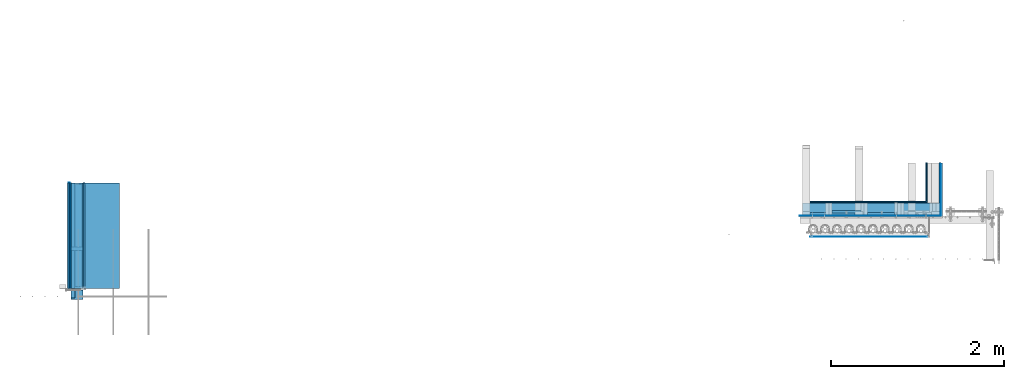
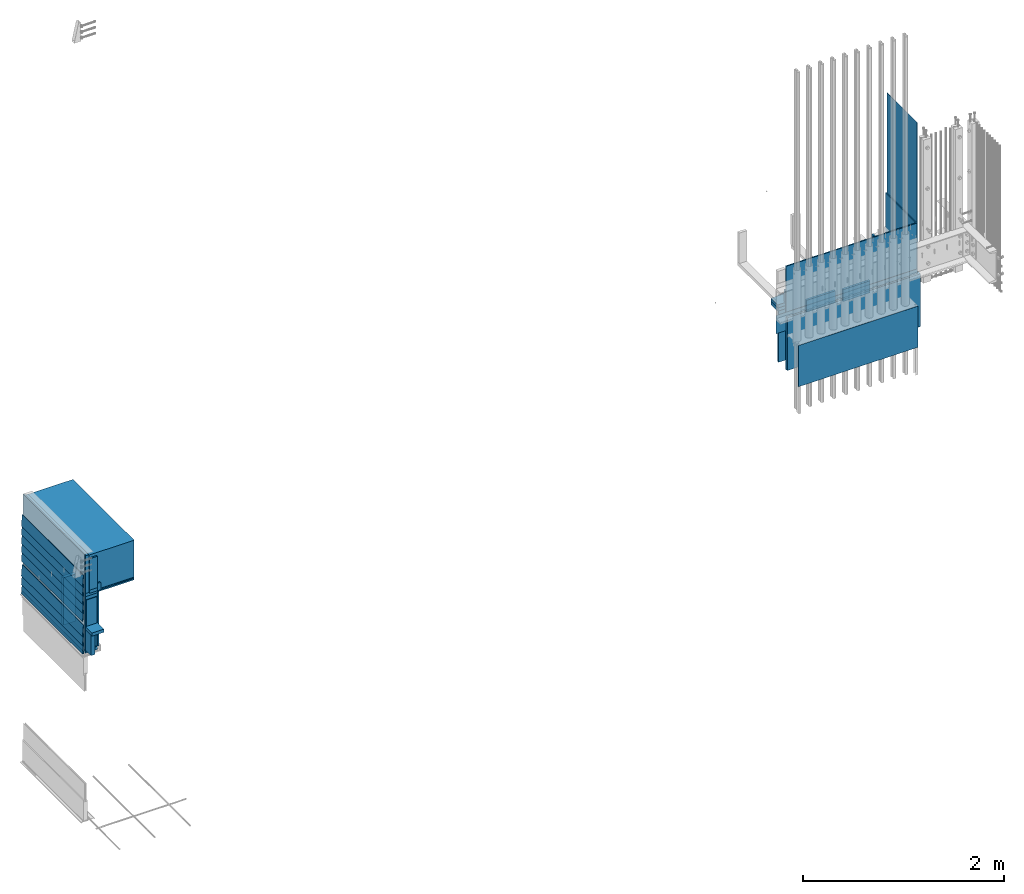
# One storey, part 1 of 44: 36 walls.
"""IFC4 building model written with IfcOpenShell, lengths in feet."""

import ifcopenshell
import ifcopenshell.guid

model = None  # the IFC model being written
_history = None  # IfcOwnerHistory: only IFC2X3 demands one
_inside = {}  # id of a spatial element -> (the spatial element, [elements in it])
_under = {}  # id of a project, library or spatial element -> (it, [spatial elements below it])
_declared = {}  # id of a project -> (the project, [libraries it declares])
_typed = {}  # id of a type object -> (the type object, [elements of that type])
_made_of = {}  # id of a material, layer set ... -> (it, [elements and type objects made of it])


def new_model(schema):
    """Start an empty IFC model of exactly this schema.

    Asked for "IFC4X3", IfcOpenShell would pick the latest addendum, in which some entities
    have other attributes; the version numbers below select the first issue.
    IFC2X3 requires an IfcOwnerHistory on every rooted entity: one is made here for all.
    """
    global model, _history
    if schema == "IFC4X3":
        model = ifcopenshell.file(schema_version=(4, 3, 0, 0))
    else:
        model = ifcopenshell.file(schema=schema)
    _inside.clear()
    _under.clear()
    _declared.clear()
    _typed.clear()
    _made_of.clear()
    _history = None
    if model.schema == "IFC2X3":
        org = make("IfcOrganization", Name="unknown")
        user = make(
            "IfcPersonAndOrganization",
            ThePerson=make("IfcPerson", FamilyName="unknown"),
            TheOrganization=org,
        )
        app = make(
            "IfcApplication",
            ApplicationDeveloper=org,
            Version="unknown",
            ApplicationFullName="unknown",
            ApplicationIdentifier="unknown",
        )
        _history = make(
            "IfcOwnerHistory",
            OwningUser=user,
            OwningApplication=app,
            ChangeAction="ADDED",
            CreationDate=0,
        )
    return model


def make(cls, **values):
    """One entity of the class cls with the attributes given. An attribute that is None is left unset."""
    return model.create_entity(
        cls, **{name: value for name, value in values.items() if value is not None}
    )


def entity(cls, *values):
    """Any entity or typed value of the class cls, its attributes in the order of the schema. None: left unset."""
    e = model.create_entity(cls)
    for i, value in enumerate(values):
        if value is not None:
            e[i] = value
    return e


def rooted(cls, **values):
    """An entity with a GlobalId (a new one), such as an element, a storey or a relation."""
    return make(cls, GlobalId=ifcopenshell.guid.new(), OwnerHistory=_history, **values)


def si_unit(unit_type, name, prefix=None):
    """IfcSIUnit, for example si_unit("LENGTHUNIT", "METRE", prefix="MILLI")."""
    return make("IfcSIUnit", UnitType=unit_type, Prefix=prefix, Name=name)


def converted_unit(unit_type, name, factor, base, dimensions=None, offset=None):
    """IfcConversionBasedUnit, such as the inch: factor (a typed value) times the base unit."""
    return make(
        "IfcConversionBasedUnit"
        if offset is None
        else "IfcConversionBasedUnitWithOffset",
        ConversionOffset=offset,
        Dimensions=None
        if dimensions is None
        else entity("IfcDimensionalExponents", *dimensions),
        UnitType=unit_type,
        Name=name,
        ConversionFactor=make(
            "IfcMeasureWithUnit", ValueComponent=factor, UnitComponent=base
        ),
    )


def derived_unit(unit_type, elements):
    """IfcDerivedUnit: a product of units, each with its exponent."""
    return make(
        "IfcDerivedUnit",
        Elements=[
            make("IfcDerivedUnitElement", Unit=unit, Exponent=power)
            for unit, power in elements
        ],
        UnitType=unit_type,
    )


def assignment(units):
    """IfcUnitAssignment: the units of a project."""
    return None if units is None else make("IfcUnitAssignment", Units=units)


def point(xyz):
    """IfcCartesianPoint."""
    return None if xyz is None else make("IfcCartesianPoint", Coordinates=xyz)


def direction(xyz):
    """IfcDirection."""
    return None if xyz is None else make("IfcDirection", DirectionRatios=xyz)


def frame(location, z_axis=None, x_axis=None):
    """IfcAxis2Placement3D, a coordinate frame: its origin and axes. An axis left out is left unset."""
    return make(
        "IfcAxis2Placement3D",
        Location=point(location),
        Axis=direction(z_axis),
        RefDirection=direction(x_axis),
    )


def frame_2d(location, x_axis=None):
    """IfcAxis2Placement2D, a coordinate frame in the plane: its origin and x axis."""
    return make(
        "IfcAxis2Placement2D", Location=point(location), RefDirection=direction(x_axis)
    )


def origin():
    """The frame at (0, 0, 0) with its axes left unset."""
    return frame((0.0, 0.0, 0.0))


def origin_2d_with_axis():
    """The frame at (0, 0) in the plane with the x axis (1, 0) written out."""
    return frame_2d((0.0, 0.0), x_axis=(1.0, 0.0))


def place(relative_to, where):
    """IfcLocalPlacement: puts the frame where relative to a parent placement (None: the world)."""
    return make(
        "IfcLocalPlacement", PlacementRelTo=relative_to, RelativePlacement=where
    )


def context(
    kind, dimensions, precision=None, world=None, true_north=None, identifier=None
):
    """IfcGeometricRepresentationContext, for example the 3D "Model" context."""
    return make(
        "IfcGeometricRepresentationContext",
        ContextIdentifier=identifier,
        ContextType=kind,
        CoordinateSpaceDimension=dimensions,
        Precision=precision,
        WorldCoordinateSystem=world,
        TrueNorth=true_north,
    )


def subcontext(parent, identifier, kind, view, scale=None):
    """IfcGeometricRepresentationSubContext, for example "Body" below "Model"."""
    return make(
        "IfcGeometricRepresentationSubContext",
        ContextIdentifier=identifier,
        ContextType=kind,
        ParentContext=parent,
        TargetScale=scale,
        TargetView=view,
    )


def project(units=None, contexts=None):
    """IfcProject with its units and contexts."""
    return rooted(
        "IfcProject",
        Name="project",
        RepresentationContexts=contexts,
        UnitsInContext=assignment(units),
    )


def spatial(cls, under=None, at=None, **own):
    """A site, building, storey or space (cls), placed at a placement, below another one or the project."""
    s = rooted(cls, ObjectPlacement=at, **own)
    if under is not None:
        _under.setdefault(under.id(), (under, []))[1].append(s)
    return s


def polyline(points):
    """IfcPolyline through the points."""
    return make("IfcPolyline", Points=[point(p) for p in points])


def profile(cls, at=None, kind="AREA", **sizes):
    """A parametric profile (cls). Its sizes go by their IFC names, for example OverallWidth=200.0."""
    return make(cls, ProfileType=kind, Position=at, **sizes)


def rectangle(**sizes):
    """IfcRectangleProfileDef."""
    return profile("IfcRectangleProfileDef", **sizes)


def outline(outer, holes=None, kind="AREA"):
    """IfcArbitraryClosedProfileDef: a profile drawn as a closed curve; with holes, ...WithVoids."""
    if holes is None:
        return make("IfcArbitraryClosedProfileDef", ProfileType=kind, OuterCurve=outer)
    return make(
        "IfcArbitraryProfileDefWithVoids",
        ProfileType=kind,
        OuterCurve=outer,
        InnerCurves=holes,
    )


def extrude(swept, where, along, depth):
    """IfcExtrudedAreaSolid: the profile swept, set in the frame where, extruded along a direction by depth."""
    return make(
        "IfcExtrudedAreaSolid",
        SweptArea=swept,
        Position=where,
        ExtrudedDirection=direction(along),
        Depth=depth,
    )


def shape(context_of_items, identifier, shape_type, items):
    """IfcShapeRepresentation: the items that make up one representation, for example the "Body"."""
    return make(
        "IfcShapeRepresentation",
        ContextOfItems=context_of_items,
        RepresentationIdentifier=identifier,
        RepresentationType=shape_type,
        Items=items,
    )


def material(Name=None, Category=None):
    """IfcMaterial."""
    return make("IfcMaterial", Name=Name, Category=Category)


def made_of(thing, what):
    """Note that an element or type object is made of a material, layer set ...; save() writes the relation."""
    if what is not None:
        _made_of.setdefault(what.id(), (what, []))[1].append(thing)
    return thing


def type_object(cls, material=None, **own):
    """A type object (cls), such as IfcWallType, which elements share."""
    return made_of(rooted(cls, **own), material)


def element(
    cls,
    number,
    at=None,
    inside=None,
    cuts=None,
    type_object=None,
    material=None,
    context=None,
    identifier="Body",
    shape_type=None,
    held_by="IfcProductDefinitionShape",
    body=None,
    shapes=None,
    **own,
):
    """One element of the class cls, such as IfcWall. Its Tag is "e" and its number.

    at: its placement. inside: the storey or other place that contains it. cuts: it is an
    opening in that element (IfcRelVoidsElement). A single representation is given by context,
    identifier, shape_type and body (its items); several are given by shapes. held_by: the class
    of the entity that holds the representations. save() writes the other relations.
    """
    e = rooted(cls, Tag="e%d" % number, ObjectPlacement=at, **own)
    if body is not None:
        shapes = [shape(context, identifier, shape_type, body)]
    if shapes is not None:
        e.Representation = make(held_by, Representations=shapes)
    if inside is not None:
        _inside.setdefault(inside.id(), (inside, []))[1].append(e)
    if cuts is not None:
        rooted(
            "IfcRelVoidsElement", RelatingBuildingElement=cuts, RelatedOpeningElement=e
        )
    if type_object is not None:
        _typed.setdefault(type_object.id(), (type_object, []))[1].append(e)
    return made_of(e, material)


def aggregate(whole, parts):
    """IfcRelAggregates: a whole, such as a stair, and the parts it consists of."""
    return rooted("IfcRelAggregates", RelatingObject=whole, RelatedObjects=parts)


def save(model, path):
    """Write the relations noted so far, then the file.

    IfcRelAggregates (storeys below a building ...), IfcRelContainedInSpatialStructure (elements
    in a storey), IfcRelDefinesByType, IfcRelAssociatesMaterial and IfcRelDeclares: one each for
    every whole, place, type object, material and project.
    """
    for whole, parts in _under.values():
        aggregate(whole, parts)
    for where, things in _inside.values():
        rooted(
            "IfcRelContainedInSpatialStructure",
            RelatedElements=things,
            RelatingStructure=where,
        )
    for kind, things in _typed.values():
        rooted("IfcRelDefinesByType", RelatedObjects=things, RelatingType=kind)
    for what, things in _made_of.values():
        rooted("IfcRelAssociatesMaterial", RelatedObjects=things, RelatingMaterial=what)
    for by, libraries in _declared.values():
        rooted("IfcRelDeclares", RelatingContext=by, RelatedDefinitions=libraries)
    model.write(path)


model = new_model("IFC4")

# Units and contexts
model_context = context("Model", 3, precision=0.0001, world=origin(), true_north=direction((6.12303176911189e-17, 1.0)))
body_context = subcontext(model_context, "Body", "Model", "MODEL_VIEW")
ifc_project = project(units=[converted_unit("LENGTHUNIT", "FOOT", entity("IfcRatioMeasure", 0.3048), si_unit("LENGTHUNIT", "METRE"), dimensions=[1, 0, 0, 0, 0, 0, 0]), converted_unit("AREAUNIT", "SQUARE FOOT", entity("IfcRatioMeasure", 0.09290304), si_unit("AREAUNIT", "SQUARE_METRE"), dimensions=[2, 0, 0, 0, 0, 0, 0]), converted_unit("VOLUMEUNIT", "CUBIC FOOT", entity("IfcRatioMeasure", 0.028316846592), si_unit("VOLUMEUNIT", "CUBIC_METRE"), dimensions=[3, 0, 0, 0, 0, 0, 0]), converted_unit("PLANEANGLEUNIT", "DEGREE", entity("IfcRatioMeasure", 0.0174532925199433), si_unit("PLANEANGLEUNIT", "RADIAN"), dimensions=[0, 0, 0, 0, 0, 0, 0]), si_unit("MASSUNIT", "GRAM", prefix="KILO"), derived_unit("MASSDENSITYUNIT", [(si_unit("MASSUNIT", "GRAM", prefix="KILO"), 1), (si_unit("LENGTHUNIT", "METRE"), -3)]), derived_unit("MOMENTOFINERTIAUNIT", [(si_unit("LENGTHUNIT", "METRE"), 4)]), si_unit("TIMEUNIT", "SECOND"), si_unit("FREQUENCYUNIT", "HERTZ"), si_unit("THERMODYNAMICTEMPERATUREUNIT", "DEGREE_CELSIUS"), derived_unit("THERMALTRANSMITTANCEUNIT", [(si_unit("MASSUNIT", "GRAM", prefix="KILO"), 1), (si_unit("THERMODYNAMICTEMPERATUREUNIT", "KELVIN"), -1), (si_unit("TIMEUNIT", "SECOND"), -3)]), derived_unit("VOLUMETRICFLOWRATEUNIT", [(si_unit("LENGTHUNIT", "METRE"), 3), (si_unit("TIMEUNIT", "SECOND"), -1)]), si_unit("ELECTRICCURRENTUNIT", "AMPERE"), si_unit("ELECTRICVOLTAGEUNIT", "VOLT"), si_unit("POWERUNIT", "WATT"), si_unit("FORCEUNIT", "NEWTON"), si_unit("ILLUMINANCEUNIT", "LUX"), si_unit("LUMINOUSFLUXUNIT", "LUMEN"), si_unit("LUMINOUSINTENSITYUNIT", "CANDELA"), derived_unit("USERDEFINED", [(si_unit("MASSUNIT", "GRAM", prefix="KILO"), -1), (si_unit("LENGTHUNIT", "METRE"), -2), (si_unit("TIMEUNIT", "SECOND"), 3), (si_unit("LUMINOUSFLUXUNIT", "LUMEN"), 1)]), derived_unit("LINEARVELOCITYUNIT", [(si_unit("LENGTHUNIT", "METRE"), 1), (si_unit("TIMEUNIT", "SECOND"), -1)]), si_unit("PRESSUREUNIT", "PASCAL"), derived_unit("USERDEFINED", [(si_unit("LENGTHUNIT", "METRE"), -2), (si_unit("MASSUNIT", "GRAM", prefix="KILO"), 1), (si_unit("TIMEUNIT", "SECOND"), -2)]), derived_unit("LINEARFORCEUNIT", [(si_unit("MASSUNIT", "GRAM", prefix="KILO"), 1), (si_unit("LENGTHUNIT", "METRE"), 1), (si_unit("TIMEUNIT", "SECOND"), -2), (si_unit("LENGTHUNIT", "METRE"), -1)]), derived_unit("PLANARFORCEUNIT", [(si_unit("MASSUNIT", "GRAM", prefix="KILO"), 1), (si_unit("LENGTHUNIT", "METRE"), 1), (si_unit("TIMEUNIT", "SECOND"), -2), (si_unit("LENGTHUNIT", "METRE"), -2)])], contexts=[model_context])

# Site, building, storey
site_placement = place(None, origin())
site = spatial("IfcSite", under=ifc_project, at=site_placement, CompositionType="ELEMENT")
building_placement = place(site_placement, origin())
building = spatial("IfcBuilding", under=site, at=building_placement, CompositionType="ELEMENT")
storey_placement = place(building_placement, origin())
storey = spatial("IfcBuildingStorey", under=building, at=storey_placement, CompositionType="ELEMENT", Elevation=0.0)

# Walls
ifc_material_1 = material(Name="WOOD TOP PLATE", Category="Materials")
wall_type_1 = type_object("IfcWallType", Name="Generic Models 630:Generic Models 1", PredefinedType="NOTDEFINED", material=ifc_material_1)
wall_1_placement = place(storey_placement, frame((1459.31080872048, 2.0, 6.71878516513966), z_axis=(0.0, 0.0, 1.0), x_axis=(0.0, 1.0, 0.0)))
element("IfcWall", 1, at=wall_1_placement, inside=storey, type_object=wall_type_1, material=ifc_material_1, Name="Generic Models 630:Generic Models 1", ObjectType="Generic Models 630:Generic Models 1", PredefinedType="NOTDEFINED", context=body_context, shape_type="SweptSolid", body=[
    extrude(rectangle(XDim=4.0, YDim=0.458333333333258, at=frame_2d((0.0, -1.13686837721616e-13), x_axis=(1.0, 0.0))), frame((2.0, -0.229166666666515, 0.0)), (0.0, 0.0, 1.0), 0.124999999999999),
])
ifc_material_2 = material(Name="DOUBLE 2X WOOD TOP PLATE", Category="Materials")
wall_type_2 = type_object("IfcWallType", Name="Generic Models 637:Generic Models 1", PredefinedType="NOTDEFINED", material=ifc_material_2)
wall_2_placement = place(storey_placement, frame((1459.31080872048, 2.0, 8.97916666666606), z_axis=(0.0, 0.0, 1.0), x_axis=(0.0, 1.0, 0.0)))
element("IfcWall", 2, at=wall_2_placement, inside=storey, type_object=wall_type_2, material=ifc_material_2, Name="Generic Models 637:Generic Models 1", ObjectType="Generic Models 637:Generic Models 1", PredefinedType="NOTDEFINED", context=body_context, shape_type="SweptSolid", body=[
    extrude(rectangle(XDim=4.0, YDim=0.458333333333485, at=frame_2d((0.0, -2.27373675443232e-13), x_axis=(1.0, 0.0))), frame((2.0, -0.229166666666515, 0.0)), (0.0, 0.0, 1.0), 0.125),
])
ifc_material_3 = material(Name="FIBER CEMENT", Category="Materials")
wall_type_3 = type_object("IfcWallType", Name="Generic Models 639:Generic Models 1", PredefinedType="NOTDEFINED", material=ifc_material_3)
wall_3_placement = place(storey_placement, frame((1459.19227841188, 2.0, 6.72139923807334), z_axis=(0.0, 0.0, 1.0), x_axis=(0.0, 1.0, 0.0)))
element("IfcWall", 3, at=wall_3_placement, inside=storey, type_object=wall_type_3, material=ifc_material_3, Name="Generic Models 639:Generic Models 1", ObjectType="Generic Models 639:Generic Models 1", PredefinedType="NOTDEFINED", context=body_context, shape_type="SweptSolid", body=[
    extrude(rectangle(XDim=0.0259999999998034, YDim=4.0, at=frame_2d((3.33066907387547e-16, 3.72965547335014e-17), x_axis=(0.0, 1.0))), frame((2.0, -0.0129531737923116, 0.0011024013350962), z_axis=(0.0, -0.0848001027001101, 0.996397984031507), x_axis=(1.0, 0.0, 0.0)), (0.0, 0.0, 1.0), 0.437499999999986),
])
ifc_material_4 = material(Name="2X WOOD STUD", Category="Materials")
wall_type_4 = type_object("IfcWallType", Name="Generic Models 645:Generic Models 1", PredefinedType="NOTDEFINED", material=ifc_material_4)
wall_4_placement = place(storey_placement, frame((1459.31080872048, 3.44270833332938, 6.96874999999967)))
element("IfcWall", 4, at=wall_4_placement, inside=storey, type_object=wall_type_4, material=ifc_material_4, Name="Generic Models 645:Generic Models 1", ObjectType="Generic Models 645:Generic Models 1", PredefinedType="NOTDEFINED", context=body_context, shape_type="SweptSolid", body=[
    extrude(rectangle(XDim=0.125000000000002, YDim=0.458333333333485, at=frame_2d((2.22044604925031e-16, 0.0), x_axis=(1.0, 0.0))), frame((0.229166666666742, 0.0625000000000009, 0.0), z_axis=(0.0, 0.0, 1.0), x_axis=(0.0, 1.0, 0.0)), (0.0, 0.0, 1.0), 1.8828124999993),
])
ifc_material_5 = material(Category="Materials")
wall_type_5 = type_object("IfcWallType", Name="Generic Models 650:Generic Models 1", PredefinedType="NOTDEFINED", material=ifc_material_5)
wall_5_placement = place(storey_placement, frame((1459.44707741189, 2.0, 9.12064598454291), z_axis=(0.0, 0.0, 1.0), x_axis=(0.0, 1.0, 0.0)))
element("IfcWall", 5, at=wall_5_placement, inside=storey, type_object=wall_type_5, material=ifc_material_5, Name="Generic Models 650:Generic Models 1", ObjectType="Generic Models 650:Generic Models 1", PredefinedType="NOTDEFINED", context=body_context, shape_type="SweptSolid", body=[
    extrude(rectangle(XDim=3.99999999999999, YDim=1.70028463773406, at=frame_2d((2.22044604925031e-16, -2.27373675443232e-13), x_axis=(1.0, 0.0))), frame((2.0, -0.850142318866801, 0.0)), (0.0, 0.0, 1.0), 1.47194541112943),
])
ifc_material_6 = material(Category="Materials")
wall_type_6 = type_object("IfcWallType", Name="Generic Models 653:Generic Models 1", PredefinedType="NOTDEFINED", material=ifc_material_6)
wall_6_placement = place(storey_placement, frame((1459.76914205382, 2.0, 6.84374999999967), z_axis=(0.0, 0.0, 1.0), x_axis=(0.0, 1.0, 0.0)))
element("IfcWall", 6, at=wall_6_placement, inside=storey, type_object=wall_type_6, material=ifc_material_6, Name="Generic Models 653:Generic Models 1", ObjectType="Generic Models 653:Generic Models 1", PredefinedType="NOTDEFINED", context=body_context, shape_type="SweptSolid", body=[
    extrude(rectangle(XDim=4.0, YDim=0.0520833333334849, at=origin_2d_with_axis()), frame((2.0, -0.0260416666667425, 0.0)), (0.0, 0.0, 1.0), 2.16666666666598),
])
ifc_material_7 = material(Name="LVL RIM BOARD - SEE STRUCT", Category="Materials")
wall_type_7 = type_object("IfcWallType", Name="Generic Models 660:Generic Models 1", PredefinedType="NOTDEFINED", material=ifc_material_7)
wall_7_placement = place(storey_placement, frame((1459.31080872048, 2.0, 9.10416666666608), z_axis=(0.0, 0.0, 1.0), x_axis=(0.0, 1.0, 0.0)))
element("IfcWall", 7, at=wall_7_placement, inside=storey, type_object=wall_type_7, material=ifc_material_7, Name="Generic Models 660:Generic Models 1", ObjectType="Generic Models 660:Generic Models 1", PredefinedType="NOTDEFINED", context=body_context, shape_type="SweptSolid", body=[
    extrude(rectangle(XDim=4.0, YDim=0.125, at=frame_2d((-2.22044604925031e-16, 0.0), x_axis=(1.0, 0.0))), frame((2.0, -0.0625, 0.0)), (0.0, 0.0, 1.0), 1.50054353157724),
])
wall_type_8 = type_object("IfcWallType", Name="Generic Models 669:Generic Models 1", PredefinedType="NOTDEFINED", material=ifc_material_2)
wall_8_placement = place(storey_placement, frame((1459.31080872048, 2.0, 8.85416666666564), z_axis=(0.0, 0.0, 1.0), x_axis=(0.0, 1.0, 0.0)))
element("IfcWall", 8, at=wall_8_placement, inside=storey, type_object=wall_type_8, material=ifc_material_2, Name="Generic Models 669:Generic Models 1", ObjectType="Generic Models 669:Generic Models 1", PredefinedType="NOTDEFINED", context=body_context, shape_type="SweptSolid", body=[
    extrude(rectangle(XDim=4.0, YDim=0.458333333333258, at=frame_2d((-5.55111512312578e-16, 1.13686837721616e-13), x_axis=(1.0, 0.0))), frame((2.0, -0.229166666666742, 0.0)), (0.0, 0.0, 1.0), 0.125),
])
ifc_material_8 = material(Name="STARTER STRIP", Category="Materials")
wall_type_9 = type_object("IfcWallType", Name="Generic Models 655:Generic Models 1", PredefinedType="NOTDEFINED", material=ifc_material_8)
wall_9_placement = place(storey_placement, frame((1459.22697042052, 2.0, 6.72046375490448), z_axis=(0.0, 0.0, 1.0), x_axis=(0.0, 1.0, 0.0)))
element("IfcWall", 9, at=wall_9_placement, inside=storey, type_object=wall_type_9, material=ifc_material_8, Name="Generic Models 655:Generic Models 1", ObjectType="Generic Models 655:Generic Models 1", PredefinedType="NOTDEFINED", context=body_context, shape_type="SweptSolid", body=[
    extrude(rectangle(XDim=4.0, YDim=0.022666666666737, at=frame_2d((4.44089209850063e-16, 0.0), x_axis=(1.0, 0.0))), frame((2.0, -0.0113333333333685, 0.0)), (0.0, 0.0, 1.0), 0.104166666666667),
])
ifc_material_9 = material(Category="Materials")
wall_type_10 = type_object("IfcWallType", Name="Generic Models 629:Generic Models 1", PredefinedType="NOTDEFINED", material=ifc_material_9)
wall_10_placement = place(storey_placement, frame((1459.76914205382, 2.0, 9.01041666666564), z_axis=(0.0, 0.0, 1.0), x_axis=(0.0, 1.0, 0.0)))
element("IfcWall", 10, at=wall_10_placement, inside=storey, type_object=wall_type_10, material=ifc_material_9, Name="Generic Models 629:Generic Models 1", ObjectType="Generic Models 629:Generic Models 1", PredefinedType="NOTDEFINED", context=body_context, shape_type="SweptSolid", body=[
    extrude(rectangle(XDim=4.0, YDim=1.37821999580524, at=frame_2d((0.0, -1.13686837721616e-13), x_axis=(1.0, 0.0))), frame((2.0, -0.689109997902506, 0.0)), (0.0, 0.0, 1.0), 0.0520833333333712),
])
ifc_material_10 = material(Name="LVL HEADER - SEE STRUCT", Category="Materials")
wall_type_11 = type_object("IfcWallType", Name="Walls 13:Walls 12", PredefinedType="NOTDEFINED", material=ifc_material_10)
wall_11_placement = place(storey_placement, frame((1459.31080872048, 1.64294860637011, 6.84378516513966), z_axis=(0.0, 0.0, 1.0), x_axis=(0.0, 1.0, 0.0)))
element("IfcWall", 11, at=wall_11_placement, inside=storey, type_object=wall_type_11, material=ifc_material_10, Name="Walls 13:Walls 12", ObjectType="Walls 13:Walls 12", PredefinedType="NOTDEFINED", context=body_context, shape_type="SweptSolid", body=[
    extrude(rectangle(XDim=4.35705139362589, YDim=0.145833333333258, at=frame_2d((2.22044604925031e-16, 1.13686837721616e-13), x_axis=(1.0, 0.0))), frame((2.17852569681294, -0.0729166666667425, 0.0)), (0.0, 0.0, 1.0), 0.8125),
])
ifc_material_11 = material(Category="Materials")
wall_type_12 = type_object("IfcWallType", Name="Generic Models 683:Generic Models 1", PredefinedType="NOTDEFINED", material=ifc_material_11)
wall_12_placement = place(storey_placement, frame((1459.26948162332, 2.0, 6.84374999999966), z_axis=(0.0, 0.0, 1.0), x_axis=(0.0, 1.0, 0.0)))
element("IfcWall", 12, at=wall_12_placement, inside=storey, type_object=wall_type_12, material=ifc_material_11, Name="Generic Models 683:Generic Models 1", ObjectType="Generic Models 683:Generic Models 1", PredefinedType="NOTDEFINED", context=body_context, shape_type="SweptSolid", body=[
    extrude(rectangle(XDim=4.0, YDim=0.0416666666667425, at=frame_2d((1.11022302462516e-16, 1.13686837721616e-13), x_axis=(1.0, 0.0))), frame((2.0, -0.0208333333334849, 0.0)), (0.0, 0.0, 1.0), 3.82346019824417),
])
ifc_material_12 = material(Name="BATT INSULATION - FILL CAVITY", Category="Materials")
wall_type_13 = type_object("IfcWallType", Name="Generic Models 684:Generic Models 1", PredefinedType="NOTDEFINED", material=ifc_material_12)
wall_13_placement = place(storey_placement, frame((1459.33910407653, 2.0, 6.86946636136536), z_axis=(0.0, 0.0, 1.0), x_axis=(0.0, 1.0, 0.0)))
element("IfcWall", 13, at=wall_13_placement, inside=storey, type_object=wall_type_13, material=ifc_material_12, Name="Generic Models 684:Generic Models 1", ObjectType="Generic Models 684:Generic Models 1", PredefinedType="NOTDEFINED", context=body_context, shape_type="SweptSolid", body=[
    extrude(rectangle(XDim=4.00000000000001, YDim=0.409204643948669, at=frame_2d((2.22044604925031e-16, 2.27373675443232e-13), x_axis=(1.0, 0.0))), frame((2.0, -0.204602321974562, 0.0)), (0.0, 0.0, 1.0), 1.96198692542525),
])
wall_type_14 = type_object("IfcWallType", Name="Generic Models 652:Generic Models 1", PredefinedType="NOTDEFINED", material=ifc_material_1)
wall_14_placement = place(storey_placement, frame((1459.31080872048, 1.58333333332933, 7.65628516513967), z_axis=(0.0, 0.0, 1.0), x_axis=(0.0, 1.0, 0.0)))
element("IfcWall", 14, at=wall_14_placement, inside=storey, type_object=wall_type_14, material=ifc_material_1, Name="Generic Models 652:Generic Models 1", ObjectType="Generic Models 652:Generic Models 1", PredefinedType="NOTDEFINED", context=body_context, shape_type="SweptSolid", body=[
    extrude(rectangle(XDim=4.0, YDim=0.458333333333258, at=frame_2d((-2.22044604925031e-16, -1.13686837721616e-13), x_axis=(1.0, 0.0))), frame((2.0, -0.229166666666515, 0.0)), (0.0, 0.0, 1.0), 0.124999999999999),
])
ifc_material_13 = material(Category="Materials")
wall_type_15 = type_object("IfcWallType", Name="Generic Models 698:Generic Models 1", PredefinedType="NOTDEFINED", material=ifc_material_13)
wall_15_placement = place(storey_placement, frame((1459.76914205382, 2.0, 9.06249999999901), z_axis=(0.0, 0.0, 1.0), x_axis=(0.0, 1.0, 0.0)))
element("IfcWall", 15, at=wall_15_placement, inside=storey, type_object=wall_type_15, material=ifc_material_13, Name="Generic Models 698:Generic Models 1", ObjectType="Generic Models 698:Generic Models 1", PredefinedType="NOTDEFINED", context=body_context, shape_type="SweptSolid", body=[
    extrude(rectangle(XDim=4.0, YDim=1.37821999580524, at=frame_2d((0.0, -1.13686837721616e-13), x_axis=(1.0, 0.0))), frame((2.0, -0.689109997902506, 0.0)), (0.0, 0.0, 1.0), 0.0416666666669343),
])
wall_type_16 = type_object("IfcWallType", Name="Generic Models 671:Generic Models 1", PredefinedType="NOTDEFINED", material=ifc_material_3)
wall_16_placement = place(storey_placement, frame((1459.1949158051, 2.0, 9.41517805258402), z_axis=(0.0, 0.0, 1.0), x_axis=(0.0, 1.0, 0.0)))
element("IfcWall", 16, at=wall_16_placement, inside=storey, type_object=wall_type_16, material=ifc_material_3, Name="Generic Models 671:Generic Models 1", ObjectType="Generic Models 671:Generic Models 1", PredefinedType="NOTDEFINED", context=body_context, shape_type="SweptSolid", body=[
    extrude(rectangle(XDim=0.0242384311178397, YDim=4.0, at=frame_2d((3.33066907387547e-16, 0.0), x_axis=(0.0, 1.0))), frame((2.0, -0.0120755619509509, 0.00102771072404551), z_axis=(0.0, -0.0848001027001742, 0.996397984031501), x_axis=(1.0, 0.0, 0.0)), (0.0, 0.0, 1.0), 0.437499999999987),
])
ifc_material_14 = material(Name="WOOD TRUSS - SEE STRUCT", Category="Materials")
wall_type_17 = type_object("IfcWallType", Name="Generic Models 673:Generic Models 1", PredefinedType="NOTDEFINED", material=ifc_material_14)
wall_17_placement = place(storey_placement, frame((1459.43580872048, 1.94270833332914, 9.10416666666627), z_axis=(0.0, 0.0, 1.0), x_axis=(0.0, 1.0, 0.0)))
element("IfcWall", 17, at=wall_17_placement, inside=storey, type_object=wall_type_17, material=ifc_material_14, Name="Generic Models 673:Generic Models 1", ObjectType="Generic Models 673:Generic Models 1", PredefinedType="NOTDEFINED", context=body_context, shape_type="SweptSolid", body=[
    extrude(rectangle(XDim=4.0, YDim=0.291666666666515, at=frame_2d((2.22044604925031e-16, 0.0), x_axis=(1.0, 0.0))), frame((2.0, -0.145833333333258, 0.0)), (0.0, 0.0, 1.0), 0.125000000000002),
])
wall_type_18 = type_object("IfcWallType", Name="Generic Models 705:Generic Models 1", PredefinedType="NOTDEFINED", material=ifc_material_14)
wall_18_placement = place(storey_placement, frame((1459.43580872048, 1.94270833332914, 9.22916666666628)))
element("IfcWall", 18, at=wall_18_placement, inside=storey, type_object=wall_type_18, material=ifc_material_14, Name="Generic Models 705:Generic Models 1", ObjectType="Generic Models 705:Generic Models 1", PredefinedType="NOTDEFINED", context=body_context, shape_type="SweptSolid", body=[
    extrude(rectangle(XDim=0.125000000000002, YDim=0.291666666666515, at=frame_2d((1.11022302462516e-16, 0.0), x_axis=(1.0, 0.0))), frame((0.145833333333258, 0.0625000000000011, 0.0), z_axis=(0.0, 0.0, 1.0), x_axis=(0.0, 1.0, 0.0)), (0.0, 0.0, 1.0), 1.25),
])
ifc_material_15 = material(Name="2X BLOCKING", Category="Materials")
wall_type_19 = type_object("IfcWallType", Name="Generic Models 688:Generic Models 1", PredefinedType="NOTDEFINED", material=ifc_material_15)
wall_19_placement = place(storey_placement, frame((1459.72747538715, 1.9427083333106, 9.1041666666664), z_axis=(0.0, 0.0, 1.0), x_axis=(0.0, 1.0, 0.0)))
element("IfcWall", 19, at=wall_19_placement, inside=storey, type_object=wall_type_19, material=ifc_material_15, Name="Generic Models 688:Generic Models 1", ObjectType="Generic Models 688:Generic Models 1", PredefinedType="NOTDEFINED", context=body_context, shape_type="SweptSolid", body=[
    extrude(rectangle(XDim=4.0, YDim=0.125, at=frame_2d((2.22044604925031e-16, 0.0), x_axis=(1.0, 0.0))), frame((2.0, -0.0625000000002274, 0.0)), (0.0, 0.0, 1.0), 0.291666666666666),
])
wall_type_20 = type_object("IfcWallType", Name="Generic Models 631:Generic Models 1", PredefinedType="NOTDEFINED", material=ifc_material_3)
wall_20_placement = place(storey_placement, frame((1459.1949158051, 2.0, 9.06621971925069), z_axis=(0.0, 0.0, 1.0), x_axis=(0.0, 1.0, 0.0)))
element("IfcWall", 20, at=wall_20_placement, inside=storey, type_object=wall_type_20, material=ifc_material_3, Name="Generic Models 631:Generic Models 1", ObjectType="Generic Models 631:Generic Models 1", PredefinedType="NOTDEFINED", context=body_context, shape_type="SweptSolid", body=[
    extrude(rectangle(XDim=0.0242384311178397, YDim=4.0, at=frame_2d((3.33066907387547e-16, 0.0), x_axis=(0.0, 1.0))), frame((2.0, -0.0120755619509509, 0.00102771072404551), z_axis=(0.0, -0.0848001027001742, 0.996397984031501), x_axis=(1.0, 0.0, 0.0)), (0.0, 0.0, 1.0), 0.437499999999985),
])
wall_type_21 = type_object("IfcWallType", Name="Generic Models 657:Generic Models 1", PredefinedType="NOTDEFINED", material=ifc_material_3)
wall_21_placement = place(storey_placement, frame((1459.1949158051, 2.0, 8.71726138591735), z_axis=(0.0, 0.0, 1.0), x_axis=(0.0, 1.0, 0.0)))
element("IfcWall", 21, at=wall_21_placement, inside=storey, type_object=wall_type_21, material=ifc_material_3, Name="Generic Models 657:Generic Models 1", ObjectType="Generic Models 657:Generic Models 1", PredefinedType="NOTDEFINED", context=body_context, shape_type="SweptSolid", body=[
    extrude(rectangle(XDim=0.0242384311178397, YDim=4.0, at=frame_2d((3.33066907387547e-16, 0.0), x_axis=(0.0, 1.0))), frame((2.0, -0.0120755619509509, 0.00102771072404551), z_axis=(0.0, -0.0848001027001742, 0.996397984031501), x_axis=(1.0, 0.0, 0.0)), (0.0, 0.0, 1.0), 0.437499999999985),
])
wall_type_22 = type_object("IfcWallType", Name="Generic Models 658:Generic Models 1", PredefinedType="NOTDEFINED", material=ifc_material_3)
wall_22_placement = place(storey_placement, frame((1459.1949158051, 2.0, 8.36830305258402), z_axis=(0.0, 0.0, 1.0), x_axis=(0.0, 1.0, 0.0)))
element("IfcWall", 22, at=wall_22_placement, inside=storey, type_object=wall_type_22, material=ifc_material_3, Name="Generic Models 658:Generic Models 1", ObjectType="Generic Models 658:Generic Models 1", PredefinedType="NOTDEFINED", context=body_context, shape_type="SweptSolid", body=[
    extrude(rectangle(XDim=0.0242384311178397, YDim=4.0, at=frame_2d((3.33066907387547e-16, 0.0), x_axis=(0.0, 1.0))), frame((2.0, -0.0120755619509509, 0.00102771072404551), z_axis=(0.0, -0.0848001027001742, 0.996397984031501), x_axis=(1.0, 0.0, 0.0)), (0.0, 0.0, 1.0), 0.437499999999987),
])
wall_type_23 = type_object("IfcWallType", Name="Generic Models 663:Generic Models 1", PredefinedType="NOTDEFINED", material=ifc_material_3)
wall_23_placement = place(storey_placement, frame((1459.1949158051, 2.0, 8.01934471925068), z_axis=(0.0, 0.0, 1.0), x_axis=(0.0, 1.0, 0.0)))
element("IfcWall", 23, at=wall_23_placement, inside=storey, type_object=wall_type_23, material=ifc_material_3, Name="Generic Models 663:Generic Models 1", ObjectType="Generic Models 663:Generic Models 1", PredefinedType="NOTDEFINED", context=body_context, shape_type="SweptSolid", body=[
    extrude(rectangle(XDim=0.0242384311178397, YDim=4.0, at=frame_2d((3.33066907387547e-16, 0.0), x_axis=(0.0, 1.0))), frame((2.0, -0.0120755619509509, 0.00102771072404551), z_axis=(0.0, -0.0848001027001742, 0.996397984031501), x_axis=(1.0, 0.0, 0.0)), (0.0, 0.0, 1.0), 0.437499999999985),
])
wall_type_24 = type_object("IfcWallType", Name="Generic Models 672:Generic Models 1", PredefinedType="NOTDEFINED", material=ifc_material_3)
wall_24_placement = place(storey_placement, frame((1459.19227841188, 2.0, 7.07556590474001), z_axis=(0.0, 0.0, 1.0), x_axis=(0.0, 1.0, 0.0)))
element("IfcWall", 24, at=wall_24_placement, inside=storey, type_object=wall_type_24, material=ifc_material_3, Name="Generic Models 672:Generic Models 1", ObjectType="Generic Models 672:Generic Models 1", PredefinedType="NOTDEFINED", context=body_context, shape_type="SweptSolid", body=[
    extrude(rectangle(XDim=0.0259999999998033, YDim=4.0, at=frame_2d((3.33066907387547e-16, 3.81639164714898e-17), x_axis=(0.0, 1.0))), frame((2.0, -0.0129531737923116, 0.00110240133509532), z_axis=(0.0, -0.0848001027000422, 0.996397984031513), x_axis=(1.0, 0.0, 0.0)), (0.0, 0.0, 1.0), 0.437499999999986),
])
wall_type_25 = type_object("IfcWallType", Name="Generic Models 678:Generic Models 1", PredefinedType="NOTDEFINED", material=ifc_material_3)
wall_25_placement = place(storey_placement, frame((1459.19227841188, 2.0, 7.42973257140667), z_axis=(0.0, 0.0, 1.0), x_axis=(0.0, 1.0, 0.0)))
element("IfcWall", 25, at=wall_25_placement, inside=storey, type_object=wall_type_25, material=ifc_material_3, Name="Generic Models 678:Generic Models 1", ObjectType="Generic Models 678:Generic Models 1", PredefinedType="NOTDEFINED", context=body_context, shape_type="SweptSolid", body=[
    extrude(rectangle(XDim=0.0259999999998034, YDim=4.0, at=frame_2d((3.33066907387547e-16, 3.72965547335014e-17), x_axis=(0.0, 1.0))), frame((2.0, -0.0129531737923116, 0.0011024013350962), z_axis=(0.0, -0.0848001027001101, 0.996397984031507), x_axis=(1.0, 0.0, 0.0)), (0.0, 0.0, 1.0), 0.437499999999986),
])
ifc_material_16 = material(Name="BLOCKING TYP - SEE STRUCTURAL", Category="Materials")
wall_type_26 = type_object("IfcWallType", Name="Generic Models 737:Generic Models 1", PredefinedType="NOTDEFINED", material=ifc_material_16)
wall_26_placement = place(storey_placement, frame((1487.33128448684, 4.79237630160339, 9.2114504706865)))
element("IfcWall", 26, at=wall_26_placement, inside=storey, type_object=wall_type_26, material=ifc_material_16, Name="Generic Models 737:Generic Models 1", ObjectType="Generic Models 737:Generic Models 1", PredefinedType="NOTDEFINED", context=body_context, shape_type="SweptSolid", body=[
    extrude(rectangle(XDim=0.083333333333333, YDim=1.70833333333326, at=frame_2d((-4.44089209850063e-16, 1.13686837721616e-13), x_axis=(1.0, 0.0))), frame((0.854166666666742, 0.0416666666666723, 0.0), z_axis=(0.0, 0.0, 1.0), x_axis=(0.0, 1.0, 0.0)), (0.0, 0.0, 1.0), 0.479166666675473),
])
wall_type_27 = type_object("IfcWallType", Name="Generic Models 740:Generic Models 1", PredefinedType="NOTDEFINED", material=ifc_material_16)
wall_27_placement = place(storey_placement, frame((1489.50315948684, 4.79237630160339, 8.48228380401073)))
element("IfcWall", 27, at=wall_27_placement, inside=storey, type_object=wall_type_27, material=ifc_material_16, Name="Generic Models 740:Generic Models 1", ObjectType="Generic Models 740:Generic Models 1", PredefinedType="NOTDEFINED", context=body_context, shape_type="SweptSolid", body=[
    extrude(rectangle(XDim=0.083333333333333, YDim=1.02083333333326, at=frame_2d((-4.44089209850063e-16, 1.13686837721616e-13), x_axis=(1.0, 0.0))), frame((0.510416666666742, 0.0416666666666696, 0.0), z_axis=(0.0, 0.0, 1.0), x_axis=(0.0, 1.0, 0.0)), (0.0, 0.0, 1.0), 0.479166666675471),
])
ifc_material_17 = material(Category="Materials")
wall_type_28 = type_object("IfcWallType", Name="corrugated metal wall4:corrugated metal wall", PredefinedType="NOTDEFINED", material=ifc_material_17)
wall_28_placement = place(storey_placement, frame((1487.33128448684, 4.67346920443307, 6.56563457322429)))
element("IfcWall", 28, at=wall_28_placement, inside=storey, type_object=wall_type_28, material=ifc_material_17, Name="corrugated metal wall4:corrugated metal wall", ObjectType="corrugated metal wall4:corrugated metal wall", PredefinedType="NOTDEFINED", context=body_context, shape_type="SweptSolid", body=[
    extrude(outline(polyline([(-3.32338142432263, -0.721187350559276), (1.6981490454948, -0.721187350559276), (1.6981490454948, 1.36945803445189), (1.62523237882805, 1.36945803445189), (1.62523237882806, -0.648270683892609), (-3.32338142432263, -0.648270683892609), (-3.32338142432263, -0.721187350559276)])), frame((3.32338142432263, 0.721187350559281, 0.0)), (0.0, 0.0, 1.0), 2.1062859173843),
])
wall_type_29 = type_object("IfcWallType", Name="Generic Models 741:Generic Models 1", PredefinedType="NOTDEFINED", material=ifc_material_16)
wall_29_placement = place(storey_placement, frame((1488.16982615351, 4.86354134091662, 8.48228380401072)))
element("IfcWall", 29, at=wall_29_placement, inside=storey, type_object=wall_type_29, material=ifc_material_16, Name="Generic Models 741:Generic Models 1", ObjectType="Generic Models 741:Generic Models 1", PredefinedType="NOTDEFINED", context=body_context, shape_type="SweptSolid", body=[
    extrude(rectangle(XDim=0.083333333333333, YDim=1.08333333333326, at=frame_2d((0.0, 1.13686837721616e-13), x_axis=(1.0, 0.0))), frame((0.541666666666742, 0.0416666666666696, 0.0), z_axis=(0.0, 0.0, 1.0), x_axis=(0.0, 1.0, 0.0)), (0.0, 0.0, 1.0), 0.479166666675471),
])
wall_type_30 = type_object("IfcWallType", Name="Walls 45:Walls 13", PredefinedType="NOTDEFINED", material=ifc_material_2)
wall_30_placement = place(storey_placement, frame((1487.03961782017, 4.7923763016034, 9.0864504706862)))
element("IfcWall", 30, at=wall_30_placement, inside=storey, type_object=wall_type_30, material=ifc_material_2, Name="Walls 45:Walls 13", ObjectType="Walls 45:Walls 13", PredefinedType="NOTDEFINED", context=body_context, shape_type="SweptSolid", body=[
    extrude(rectangle(XDim=0.454009569496255, YDim=5.19270833333348, at=frame_2d((-4.44089209850063e-16, 0.0), x_axis=(1.0, 0.0))), frame((2.59635416666674, 0.227004784748136, 0.0), z_axis=(0.0, 0.0, 1.0), x_axis=(0.0, 1.0, 0.0)), (0.0, 0.0, 1.0), 0.125000000000005),
])
ifc_material_18 = material(Name="2X10 JOISTS", Category="Materials")
wall_type_31 = type_object("IfcWallType", Name="Walls 46:Walls 13", PredefinedType="NOTDEFINED", material=ifc_material_18)
wall_31_placement = place(storey_placement, frame((1487.03961782017, 4.7923763016034, 8.9614504706862)))
element("IfcWall", 31, at=wall_31_placement, inside=storey, type_object=wall_type_31, material=ifc_material_18, Name="Walls 46:Walls 13", ObjectType="Walls 46:Walls 13", PredefinedType="NOTDEFINED", context=body_context, shape_type="SweptSolid", body=[
    extrude(rectangle(XDim=0.454009569496246, YDim=5.19270833333348, at=frame_2d((4.44089209850063e-16, 0.0), x_axis=(1.0, 0.0))), frame((2.59635416666674, 0.227004784748131, 0.0), z_axis=(0.0, 0.0, 1.0), x_axis=(0.0, 1.0, 0.0)), (0.0, 0.0, 1.0), 0.125000000000007),
])
wall_type_32 = type_object("IfcWallType", Name="corrugated metal wall11:corrugated metal wall", PredefinedType="NOTDEFINED", material=ifc_material_11)
wall_32_placement = place(storey_placement, frame((1487.33486521601, 4.75070963493673, 6.54720060351689)))
element("IfcWall", 32, at=wall_32_placement, inside=storey, type_object=wall_type_32, material=ifc_material_11, Name="corrugated metal wall11:corrugated metal wall", ObjectType="corrugated metal wall11:corrugated metal wall", PredefinedType="NOTDEFINED", context=body_context, shape_type="SweptSolid", body=[
    extrude(outline(polyline([(-3.28116693543552, -0.68519963465725), (1.66129220420408, -0.68519963465725), (1.66129220420407, 1.32873260264783), (1.61987473123122, 1.32873260264783), (1.61987473123122, -0.643532967990584), (-3.28116693543552, -0.643532967990584), (-3.28116693543552, -0.68519963465725)])), frame((3.28116693543552, 0.685199634657256, 0.0)), (0.0, 0.0, 1.0), 4.13006516135684),
])
wall_type_33 = type_object("IfcWallType", Name="corrugated metal wall8:corrugated metal wall", PredefinedType="NOTDEFINED", material=ifc_material_6)
wall_33_placement = place(storey_placement, frame((1487.33128448684, 5.24638587109965, 6.54720060351688)))
element("IfcWall", 33, at=wall_33_placement, inside=storey, type_object=wall_type_33, material=ifc_material_6, Name="corrugated metal wall8:corrugated metal wall", ObjectType="corrugated metal wall8:corrugated metal wall", PredefinedType="NOTDEFINED", context=body_context, shape_type="SweptSolid", body=[
    extrude(outline(polyline([(-2.94444444444457, -0.523446444825163), (1.49826388888892, -0.523446444825163), (1.49826388888891, 0.994809556316993), (1.44618055555565, 0.994809556316993), (1.44618055555566, -0.47136311149183), (-2.94444444444457, -0.47136311149183), (-2.94444444444457, -0.523446444825163)])), frame((2.94444444444457, 0.523446444825168, 0.0)), (0.0, 0.0, 1.0), 2.66424986716962),
])
ifc_material_19 = material(Name="BUILDING WRAP", Category="Materials")
wall_type_34 = type_object("IfcWallType", Name="Generic Models 721:Generic Models 1", PredefinedType="NOTDEFINED", material=ifc_material_19)
wall_34_placement = place(storey_placement, frame((1492.27732435565, 4.74973307243672, 8.15386940570922), z_axis=(0.0, 0.0, 1.0), x_axis=(0.0, 1.0, 0.0)))
element("IfcWall", 34, at=wall_34_placement, inside=storey, type_object=wall_type_34, material=ifc_material_19, Name="Generic Models 721:Generic Models 1", ObjectType="Generic Models 721:Generic Models 1", PredefinedType="NOTDEFINED", context=body_context, shape_type="SweptSolid", body=[
    extrude(rectangle(XDim=0.00262500048620495, YDim=1.96562544544443, at=origin_2d_with_axis()), frame((0.982812722722215, -0.00131250024310248, 0.0), z_axis=(0.0, 0.0, 1.0), x_axis=(0.0, -1.0, 0.0)), (0.0, 0.0, 1.0), 6.52777197374708),
])
wall_type_35 = type_object("IfcWallType", Name="Generic Models 752:Generic Models 1", PredefinedType="NOTDEFINED", material=ifc_material_19)
wall_35_placement = place(storey_placement, frame((1486.94745796881, 4.74756605079636, 8.12139368374669)))
element("IfcWall", 35, at=wall_35_placement, inside=storey, type_object=wall_type_35, material=ifc_material_19, Name="Generic Models 752:Generic Models 1", ObjectType="Generic Models 752:Generic Models 1", PredefinedType="NOTDEFINED", context=body_context, shape_type="SweptSolid", body=[
    extrude(rectangle(XDim=5.33054358444519, YDim=0.0031435841403642, at=frame_2d((1.13686837721616e-13, -4.44089209850063e-16), x_axis=(1.0, 0.0))), frame((2.66527179222248, 0.00157179207022651, 0.0)), (0.0, 0.0, 1.0), 0.728730326319056),
])
ifc_material_20 = material(Name="16 GA. PERFORATED GALV. STEEL PANEL", Category="Materials")
wall_type_36 = type_object("IfcWallType", Name="PERFORATED GALV. STEEL PANEL1:PERFORATED GALV. STEEL PANEL", PredefinedType="NOTDEFINED", material=ifc_material_20)
wall_36_placement = place(storey_placement, frame((1487.33128448684, 3.95465893651114, 6.35379761447137)))
element("IfcWall", 36, at=wall_36_placement, inside=storey, type_object=wall_type_36, material=ifc_material_20, Name="PERFORATED GALV. STEEL PANEL1:PERFORATED GALV. STEEL PANEL", ObjectType="PERFORATED GALV. STEEL PANEL1:PERFORATED GALV. STEEL PANEL", PredefinedType="NOTDEFINED", context=body_context, shape_type="SweptSolid", body=[
    extrude(rectangle(XDim=4.5162804698175, YDim=0.0052500000000042, at=frame_2d((0.0, -3.77475828372553e-15), x_axis=(1.0, 0.0))), frame((2.25814023490875, 0.00262500000000587, 0.0), z_axis=(0.0, 0.0, 1.0), x_axis=(-1.0, 0.0, 0.0)), (0.0, 0.0, 1.0), 1.64421029079259),
])

save(model, "model.ifc")
